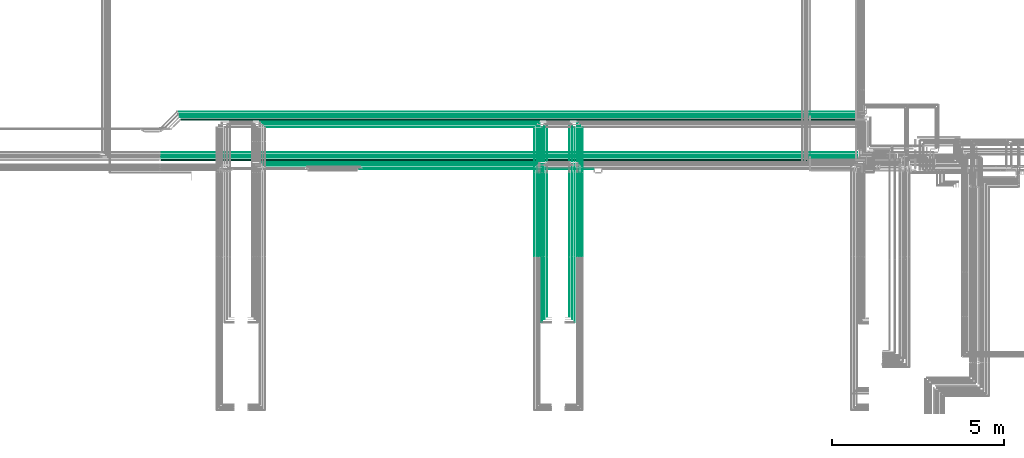
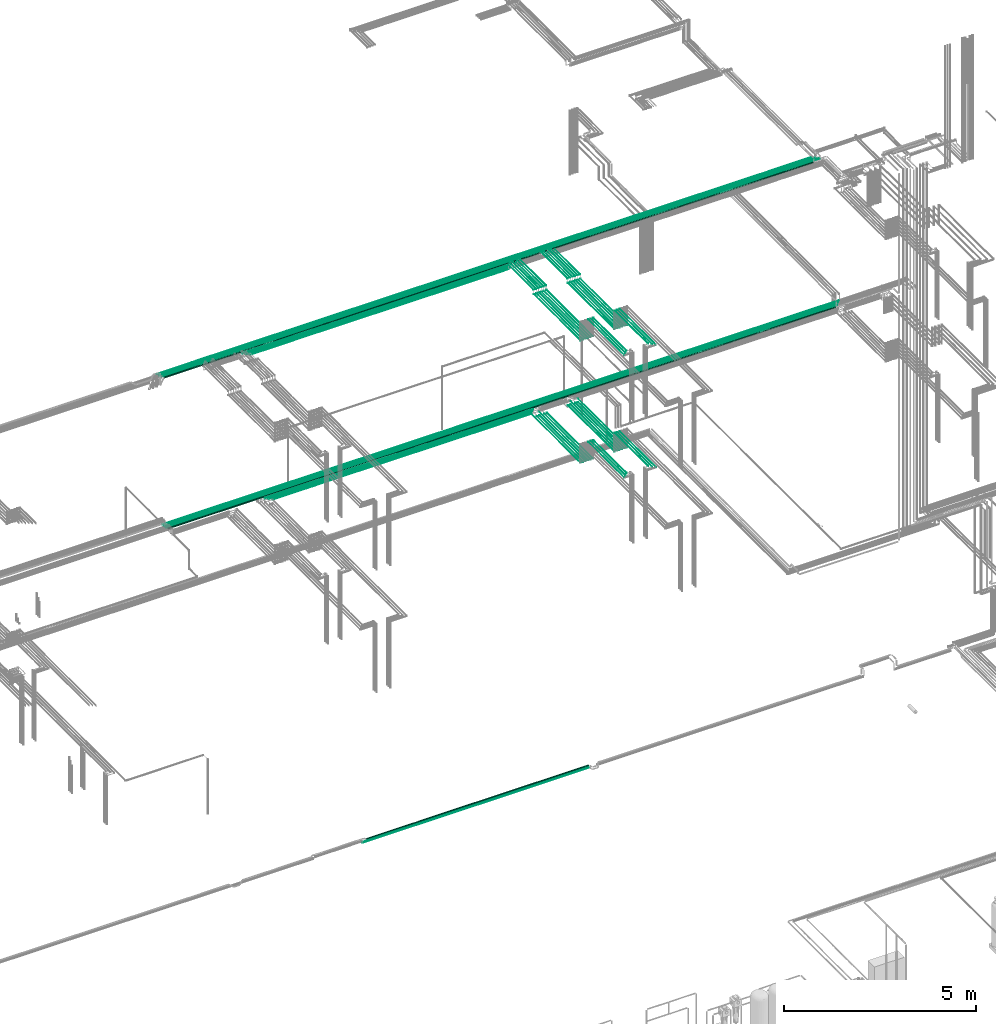
# One storey, part 63 of 331: 64 flow segments.
"""IFC2X3 building model written with IfcOpenShell, lengths in millimetres."""

from ifc_helpers import new_model, entity, si_unit, converted_unit, derived_unit, direction, frame, frame_2d, origin, origin_2d_with_axis, place, context, subcontext, project, spatial, circle, extrude, type_object, element, save


model = new_model("IFC2X3")

# Units and contexts
model_context = context("Model", 3, precision=0.01, world=origin(), true_north=direction((6.12303176911189e-17, 1.0)))
body_context = subcontext(model_context, "Body", "Model", "MODEL_VIEW")
ifc_project = project(units=[si_unit("LENGTHUNIT", "METRE", prefix="MILLI"), si_unit("AREAUNIT", "SQUARE_METRE"), si_unit("VOLUMEUNIT", "CUBIC_METRE"), converted_unit("PLANEANGLEUNIT", "DEGREE", entity("IfcRatioMeasure", 0.0174532925199433), si_unit("PLANEANGLEUNIT", "RADIAN"), dimensions=[0, 0, 0, 0, 0, 0, 0]), si_unit("MASSUNIT", "GRAM", prefix="KILO"), derived_unit("MASSDENSITYUNIT", [(si_unit("MASSUNIT", "GRAM", prefix="KILO"), 1), (si_unit("LENGTHUNIT", "METRE"), -3)]), derived_unit("MOMENTOFINERTIAUNIT", [(si_unit("LENGTHUNIT", "METRE"), 4)]), si_unit("TIMEUNIT", "SECOND"), si_unit("FREQUENCYUNIT", "HERTZ"), si_unit("THERMODYNAMICTEMPERATUREUNIT", "DEGREE_CELSIUS"), derived_unit("THERMALTRANSMITTANCEUNIT", [(si_unit("MASSUNIT", "GRAM", prefix="KILO"), 1), (si_unit("THERMODYNAMICTEMPERATUREUNIT", "KELVIN"), -1), (si_unit("TIMEUNIT", "SECOND"), -3)]), derived_unit("VOLUMETRICFLOWRATEUNIT", [(si_unit("LENGTHUNIT", "METRE"), 3), (si_unit("TIMEUNIT", "SECOND"), -1)]), derived_unit("MASSFLOWRATEUNIT", [(si_unit("MASSUNIT", "GRAM", prefix="KILO"), 1), (si_unit("TIMEUNIT", "SECOND"), -1)]), derived_unit("ROTATIONALFREQUENCYUNIT", [(si_unit("TIMEUNIT", "SECOND"), -1)]), si_unit("ELECTRICCURRENTUNIT", "AMPERE"), si_unit("ELECTRICVOLTAGEUNIT", "VOLT"), si_unit("POWERUNIT", "WATT"), si_unit("FORCEUNIT", "NEWTON", prefix="KILO"), si_unit("ILLUMINANCEUNIT", "LUX"), si_unit("LUMINOUSFLUXUNIT", "LUMEN"), si_unit("LUMINOUSINTENSITYUNIT", "CANDELA"), derived_unit("USERDEFINED", [(si_unit("MASSUNIT", "GRAM", prefix="KILO"), -1), (si_unit("LENGTHUNIT", "METRE"), -2), (si_unit("TIMEUNIT", "SECOND"), 3), (si_unit("LUMINOUSFLUXUNIT", "LUMEN"), 1)]), derived_unit("LINEARVELOCITYUNIT", [(si_unit("LENGTHUNIT", "METRE"), 1), (si_unit("TIMEUNIT", "SECOND"), -1)]), si_unit("PRESSUREUNIT", "PASCAL"), derived_unit("USERDEFINED", [(si_unit("LENGTHUNIT", "METRE"), -2), (si_unit("MASSUNIT", "GRAM", prefix="KILO"), 1), (si_unit("TIMEUNIT", "SECOND"), -2)]), derived_unit("LINEARFORCEUNIT", [(si_unit("MASSUNIT", "GRAM", prefix="KILO"), 1), (si_unit("LENGTHUNIT", "METRE"), 1), (si_unit("TIMEUNIT", "SECOND"), -2), (si_unit("LENGTHUNIT", "METRE"), -1)]), derived_unit("PLANARFORCEUNIT", [(si_unit("MASSUNIT", "GRAM", prefix="KILO"), 1), (si_unit("LENGTHUNIT", "METRE"), 1), (si_unit("TIMEUNIT", "SECOND"), -2), (si_unit("LENGTHUNIT", "METRE"), -2)])], contexts=[model_context])

# Site, building, storey
site_placement = place(None, frame((0.0, -0.00077364408347762, 0.0)))
site = spatial("IfcSite", under=ifc_project, at=site_placement, CompositionType="ELEMENT")
building_placement = place(site_placement, origin())
building = spatial("IfcBuilding", under=site, at=building_placement, CompositionType="ELEMENT")
storey_placement = place(building_placement, origin())
storey = spatial("IfcBuildingStorey", under=building, at=storey_placement, CompositionType="ELEMENT", Elevation=0.0)

# Flow segments
pipe_segment_type = type_object("IfcPipeSegmentType", PredefinedType="NOTDEFINED")
flow_segment_1_placement = place(storey_placement, frame((41835.1806039076, 8668.02529159145, 14542.4047277641)))
element("IfcFlowSegment", 1, at=flow_segment_1_placement, inside=storey, type_object=pipe_segment_type, context=body_context, shape_type="SweptSolid", body=[
    extrude(circle(Radius=6.0, at=frame_2d((0.0, 2.16573425859679e-12), x_axis=(1.0, 0.0))), frame((0.0, 7.59527223591562, 7.59527223591454), z_axis=(1.0, 0.0, 0.0), x_axis=(0.0, 1.0, 0.0)), (0.0, 0.0, 1.0), 20377.9279273853),
])
flow_segment_2_placement = place(storey_placement, frame((53840.5223318378, 5653.62056382735, 14544.4047277641)))
element("IfcFlowSegment", 2, at=flow_segment_2_placement, inside=storey, type_object=pipe_segment_type, context=body_context, shape_type="SweptSolid", body=[
    extrude(circle(Radius=4.0, at=origin_2d_with_axis()), frame((5.59527223594098, 0.0, 5.59527223591499), z_axis=(0.0, 1.0, 0.0), x_axis=(1.0, 0.0, 0.0)), (0.0, 0.0, 1.0), 2559.0),
])
flow_segment_3_placement = place(storey_placement, frame((54065.5223318378, 5653.62056382734, 14544.4047277641)))
element("IfcFlowSegment", 3, at=flow_segment_3_placement, inside=storey, type_object=pipe_segment_type, context=body_context, shape_type="SweptSolid", body=[
    extrude(circle(Radius=4.0, at=origin_2d_with_axis()), frame((5.59527223593232, 0.0, 5.59527223591499), z_axis=(0.0, 1.0, 0.0), x_axis=(1.0, 0.0, 0.0)), (0.0, 0.0, 1.0), 2559.0),
])
for number, where in (
    (4, (53765.5223318378, 5653.62056382735, 14544.4047277641)),
    (5, (53990.5223318378, 5653.62056382735, 14544.4047277641)),
):
    element("IfcFlowSegment", number, at=place(storey_placement, frame(where)), inside=storey, type_object=pipe_segment_type, context=body_context, shape_type="SweptSolid", body=[
        extrude(circle(Radius=4.0, at=origin_2d_with_axis()), frame((5.59527223591499, 0.0, 5.59527223591499), z_axis=(0.0, 1.0, 0.0), x_axis=(-1.0, 0.0, 0.0)), (0.0, 0.0, 1.0), 2422.38938002197),
    ])
flow_segment_4_placement = place(storey_placement, frame((53688.5223318378, 5657.62056382735, 14542.4047277641)))
element("IfcFlowSegment", 6, at=flow_segment_4_placement, inside=storey, type_object=pipe_segment_type, context=body_context, shape_type="SweptSolid", body=[
    extrude(circle(Radius=6.0, at=frame_2d((8.66293703438714e-12, -2.16573425859679e-12), x_axis=(1.0, 0.0))), frame((7.5952722359232, 0.0, 7.59527223591887), z_axis=(0.0, 1.0, 0.0), x_axis=(-1.0, 0.0, 0.0)), (0.0, 0.0, 1.0), 2414.00000000002),
])
flow_segment_5_placement = place(storey_placement, frame((53913.5223318378, 5657.62056382735, 14542.4047277641)))
element("IfcFlowSegment", 7, at=flow_segment_5_placement, inside=storey, type_object=pipe_segment_type, context=body_context, shape_type="SweptSolid", body=[
    extrude(circle(Radius=6.0, at=frame_2d((0.0, -2.16573425859679e-12), x_axis=(1.0, 0.0))), frame((7.59527223591454, 0.0, 7.59527223591887), z_axis=(0.0, 1.0, 0.0), x_axis=(-1.0, 0.0, 0.0)), (0.0, 0.0, 1.0), 2414.00000000001),
])
flow_segment_6_placement = place(storey_placement, frame((53688.5223318378, 3905.48876707954, 15142.4047277641)))
element("IfcFlowSegment", 8, at=flow_segment_6_placement, inside=storey, type_object=pipe_segment_type, context=body_context, shape_type="SweptSolid", body=[
    extrude(circle(Radius=6.0, at=frame_2d((0.0, 2.16573425859679e-12), x_axis=(1.0, 0.0))), frame((7.59527223591454, 0.0, 7.59527223591887), z_axis=(0.0, 1.0, 0.0), x_axis=(1.0, 0.0, 0.0)), (0.0, 0.0, 1.0), 1724.13179674781),
])
flow_segment_7_placement = place(storey_placement, frame((53765.5223318378, 3826.48876707969, 15144.4047277641)))
element("IfcFlowSegment", 9, at=flow_segment_7_placement, inside=storey, type_object=pipe_segment_type, context=body_context, shape_type="SweptSolid", body=[
    extrude(circle(Radius=4.0, at=origin_2d_with_axis()), frame((5.59527223591499, 0.0, 5.59527223591499), z_axis=(0.0, 1.0, 0.0), x_axis=(1.0, 0.0, 0.0)), (0.0, 0.0, 1.0), 1807.13179674766),
])
flow_segment_8_placement = place(storey_placement, frame((53840.5223318378, 3751.48876707946, 15144.4047277641)))
element("IfcFlowSegment", 10, at=flow_segment_8_placement, inside=storey, type_object=pipe_segment_type, context=body_context, shape_type="SweptSolid", body=[
    extrude(circle(Radius=4.0, at=origin_2d_with_axis()), frame((5.59527223591499, 0.0, 5.59527223591499), z_axis=(0.0, 1.0, 0.0), x_axis=(1.0, 0.0, 0.0)), (0.0, 0.0, 1.0), 1882.13179674789),
])
flow_segment_9_placement = place(storey_placement, frame((52890.0441030245, 5653.62056382735, 14544.4047277641)))
element("IfcFlowSegment", 11, at=flow_segment_9_placement, inside=storey, type_object=pipe_segment_type, context=body_context, shape_type="SweptSolid", body=[
    extrude(circle(Radius=4.0, at=origin_2d_with_axis()), frame((5.59527223590633, 0.0, 5.59527223591499), z_axis=(0.0, 1.0, 0.0), x_axis=(1.0, 0.0, 0.0)), (0.0, 0.0, 1.0), 2559.0),
])
flow_segment_10_placement = place(storey_placement, frame((52665.0441030245, 5653.62056382735, 14544.4047277641)))
element("IfcFlowSegment", 12, at=flow_segment_10_placement, inside=storey, type_object=pipe_segment_type, context=body_context, shape_type="SweptSolid", body=[
    extrude(circle(Radius=4.0, at=origin_2d_with_axis()), frame((5.59527223591499, 0.0, 5.59527223591499), z_axis=(0.0, 1.0, 0.0), x_axis=(1.0, 0.0, 0.0)), (0.0, 0.0, 1.0), 2559.0),
])
for number, where in (
    (13, (52965.0441030245, 5653.62056382735, 14544.4047277641)),
    (14, (52740.0441030245, 5653.62056382735, 14544.4047277641)),
):
    element("IfcFlowSegment", number, at=place(storey_placement, frame(where)), inside=storey, type_object=pipe_segment_type, context=body_context, shape_type="SweptSolid", body=[
        extrude(circle(Radius=4.0, at=origin_2d_with_axis()), frame((5.59527223591499, 0.0, 5.59527223591499), z_axis=(0.0, 1.0, 0.0), x_axis=(-1.0, 0.0, 0.0)), (0.0, 0.0, 1.0), 2402.38938002197),
    ])
flow_segment_11_placement = place(storey_placement, frame((53038.0441030244, 5657.62056382735, 14542.4047277641)))
element("IfcFlowSegment", 15, at=flow_segment_11_placement, inside=storey, type_object=pipe_segment_type, context=body_context, shape_type="SweptSolid", body=[
    extrude(circle(Radius=6.0, at=frame_2d((-8.66293703438714e-12, -2.16573425859679e-12), x_axis=(1.0, 0.0))), frame((7.5952722359232, 0.0, 7.59527223591887), z_axis=(0.0, 1.0, 0.0), x_axis=(-1.0, 0.0, 0.0)), (0.0, 0.0, 1.0), 2394.00000000002),
])
flow_segment_12_placement = place(storey_placement, frame((52813.0441030245, 5657.62056382735, 14542.4047277641)))
element("IfcFlowSegment", 16, at=flow_segment_12_placement, inside=storey, type_object=pipe_segment_type, context=body_context, shape_type="SweptSolid", body=[
    extrude(circle(Radius=6.0, at=frame_2d((0.0, -2.16573425859679e-12), x_axis=(1.0, 0.0))), frame((7.59527223591454, 0.0, 7.59527223591887), z_axis=(0.0, 1.0, 0.0), x_axis=(-1.0, 0.0, 0.0)), (0.0, 0.0, 1.0), 2394.00000000001),
])
flow_segment_13_placement = place(storey_placement, frame((53038.0441030244, 3905.48876707956, 15142.4047277641)))
element("IfcFlowSegment", 17, at=flow_segment_13_placement, inside=storey, type_object=pipe_segment_type, context=body_context, shape_type="SweptSolid", body=[
    extrude(circle(Radius=6.0, at=frame_2d((0.0, 2.16573425859679e-12), x_axis=(1.0, 0.0))), frame((7.59527223591454, 0.0, 7.59527223591887), z_axis=(0.0, 1.0, 0.0), x_axis=(1.0, 0.0, 0.0)), (0.0, 0.0, 1.0), 1724.13179674779),
])
flow_segment_14_placement = place(storey_placement, frame((52965.0441030245, 3826.48876707969, 15144.4047277641)))
element("IfcFlowSegment", 18, at=flow_segment_14_placement, inside=storey, type_object=pipe_segment_type, context=body_context, shape_type="SweptSolid", body=[
    extrude(circle(Radius=4.0, at=origin_2d_with_axis()), frame((5.59527223591499, 0.0, 5.59527223591499), z_axis=(0.0, 1.0, 0.0), x_axis=(1.0, 0.0, 0.0)), (0.0, 0.0, 1.0), 1807.13179674766),
])
flow_segment_15_placement = place(storey_placement, frame((52890.0441030245, 3751.4887670795, 15144.4047277641)))
element("IfcFlowSegment", 19, at=flow_segment_15_placement, inside=storey, type_object=pipe_segment_type, context=body_context, shape_type="SweptSolid", body=[
    extrude(circle(Radius=4.0, at=origin_2d_with_axis()), frame((5.59527223591499, 0.0, 5.59527223591499), z_axis=(0.0, 1.0, 0.0), x_axis=(1.0, 0.0, 0.0)), (0.0, 0.0, 1.0), 1882.13179674785),
])
flow_segment_16_placement = place(storey_placement, frame((44877.2323745011, 8218.02529159143, 14542.4047277641)))
element("IfcFlowSegment", 20, at=flow_segment_16_placement, inside=storey, type_object=pipe_segment_type, context=body_context, shape_type="SweptSolid", body=[
    extrude(circle(Radius=6.0, at=frame_2d((-1.08286712929839e-12, 0.0), x_axis=(1.0, 0.0))), frame((0.0, 7.59527223591454, 7.5952722359167), z_axis=(1.0, 0.0, 0.0), x_axis=(0.0, -1.0, 0.0)), (0.0, 0.0, 1.0), 7786.4070007593),
])
flow_segment_17_placement = place(storey_placement, frame((44802.2303826997, 8293.02529159145, 14542.4042010996)))
element("IfcFlowSegment", 21, at=flow_segment_17_placement, inside=storey, type_object=pipe_segment_type, context=body_context, shape_type="SweptSolid", body=[
    extrude(circle(Radius=6.0, at=origin_2d_with_axis()), frame((0.000126456651605622, 7.59527223591562, 7.59527223458478), z_axis=(1.0, 0.0, 2.10761091309566e-05), x_axis=(0.0, -1.0, 0.0)), (0.0, 0.0, 1.0), 7936.40699893471),
])
flow_segment_18_placement = place(storey_placement, frame((44728.2303244212, 8366.52529159144, 14540.9040592844)))
element("IfcFlowSegment", 22, at=flow_segment_18_placement, inside=storey, type_object=pipe_segment_type, context=body_context, shape_type="SweptSolid", body=[
    extrude(circle(Radius=7.5, at=origin_2d_with_axis()), frame((0.000168554696574574, 9.09527223591636, 9.09527223402134), z_axis=(1.0, 0.0, 2.24739589642137e-05), x_axis=(0.0, -1.0, 0.0)), (0.0, 0.0, 1.0), 8084.40699860948),
])
flow_segment_19_placement = place(storey_placement, frame((41835.1806039076, 8593.02529159145, 14542.4047277641)))
element("IfcFlowSegment", 23, at=flow_segment_19_placement, inside=storey, type_object=pipe_segment_type, context=body_context, shape_type="SweptSolid", body=[
    extrude(circle(Radius=6.0, at=frame_2d((2.16573425859679e-12, -2.16573425859679e-12), x_axis=(1.0, 0.0))), frame((0.0, 7.59527223591778, 7.59527223591887), z_axis=(1.0, 0.0, 0.0), x_axis=(0.0, 1.0, 0.0)), (0.0, 0.0, 1.0), 20302.9279273852),
])
flow_segment_20_placement = place(storey_placement, frame((41845.1806039076, 8513.02529159144, 14537.4047277641)))
element("IfcFlowSegment", 24, at=flow_segment_20_placement, inside=storey, type_object=pipe_segment_type, context=body_context, shape_type="SweptSolid", body=[
    extrude(circle(Radius=11.0, at=frame_2d((2.16573425859679e-12, 0.0), x_axis=(1.0, 0.0))), frame((0.0, 12.5952722359177, 12.5952722359156), z_axis=(1.0, 0.0, 0.0), x_axis=(0.0, 1.0, 0.0)), (0.0, 0.0, 1.0), 20212.9279273852),
])
flow_segment_21_placement = place(storey_placement, frame((41861.1806039076, 8431.52529159142, 14530.904727764)))
element("IfcFlowSegment", 25, at=flow_segment_21_placement, inside=storey, type_object=pipe_segment_type, context=body_context, shape_type="SweptSolid", body=[
    extrude(circle(Radius=17.5, at=frame_2d((7.58006990508875e-12, 0.0), x_axis=(1.0, 0.0))), frame((0.0, 19.0952722359238, 19.0952722359163), z_axis=(1.0, 0.0, 0.0), x_axis=(0.0, 1.0, 0.0)), (0.0, 0.0, 1.0), 20112.9279273852),
])
flow_segment_22_placement = place(storey_placement, frame((52889.4468045266, 5653.62056382731, 18444.404727764)))
element("IfcFlowSegment", 26, at=flow_segment_22_placement, inside=storey, type_object=pipe_segment_type, context=body_context, shape_type="SweptSolid", body=[
    extrude(circle(Radius=4.0, at=origin_2d_with_axis()), frame((5.59527223591499, 0.0, 5.59527223591499), z_axis=(0.0, 1.0, 0.0), x_axis=(1.0, 0.0, 0.0)), (0.0, 0.0, 1.0), 2426.52824282761),
])
flow_segment_23_placement = place(storey_placement, frame((52664.4468045266, 5653.62056382731, 18444.4047277641)))
element("IfcFlowSegment", 27, at=flow_segment_23_placement, inside=storey, type_object=pipe_segment_type, context=body_context, shape_type="SweptSolid", body=[
    extrude(circle(Radius=4.0, at=frame_2d((8.66293703438714e-12, 0.0), x_axis=(1.0, 0.0))), frame((5.59527223591499, 0.0, 5.59527223591499), z_axis=(0.0, 1.0, 0.0), x_axis=(-1.0, 0.0, 0.0)), (0.0, 0.0, 1.0), 2426.52824282753),
])
flow_segment_24_placement = place(storey_placement, frame((52964.4468045266, 5653.62056382732, 18444.4047277641)))
element("IfcFlowSegment", 28, at=flow_segment_24_placement, inside=storey, type_object=pipe_segment_type, context=body_context, shape_type="SweptSolid", body=[
    extrude(circle(Radius=4.0, at=origin_2d_with_axis()), frame((5.59527223591499, 0.0, 5.59527223591499), z_axis=(0.0, 1.0, 0.0), x_axis=(1.0, 0.0, 0.0)), (0.0, 0.0, 1.0), 2426.5282428276),
])
flow_segment_25_placement = place(storey_placement, frame((52739.4468045266, 5653.62056382732, 18444.4047277641)))
element("IfcFlowSegment", 29, at=flow_segment_25_placement, inside=storey, type_object=pipe_segment_type, context=body_context, shape_type="SweptSolid", body=[
    extrude(circle(Radius=4.0, at=origin_2d_with_axis()), frame((5.59527223591499, 0.0, 5.59527223591499), z_axis=(0.0, 1.0, 0.0), x_axis=(-1.0, 0.0, 0.0)), (0.0, 0.0, 1.0), 2426.52824282759),
])
flow_segment_26_placement = place(storey_placement, frame((53037.4468045266, 5657.62056382733, 18442.4047277641)))
element("IfcFlowSegment", 30, at=flow_segment_26_placement, inside=storey, type_object=pipe_segment_type, context=body_context, shape_type="SweptSolid", body=[
    extrude(circle(Radius=6.0, at=origin_2d_with_axis()), frame((7.59527223591454, 0.0, 7.5952722359167), z_axis=(0.0, 1.0, 0.0), x_axis=(1.0, 0.0, 0.0)), (0.0, 0.0, 1.0), 2418.52824282759),
])
flow_segment_27_placement = place(storey_placement, frame((52812.4468045266, 5657.62056382732, 18442.4047277641)))
element("IfcFlowSegment", 31, at=flow_segment_27_placement, inside=storey, type_object=pipe_segment_type, context=body_context, shape_type="SweptSolid", body=[
    extrude(circle(Radius=6.0, at=origin_2d_with_axis()), frame((7.59527223591454, 0.0, 7.5952722359167), z_axis=(0.0, 1.0, 0.0), x_axis=(1.0, 0.0, 0.0)), (0.0, 0.0, 1.0), 2418.52824282761),
])
flow_segment_28_placement = place(storey_placement, frame((53037.4468045266, 3905.48876707967, 19042.4047277641)))
element("IfcFlowSegment", 32, at=flow_segment_28_placement, inside=storey, type_object=pipe_segment_type, context=body_context, shape_type="SweptSolid", body=[
    extrude(circle(Radius=6.0, at=origin_2d_with_axis()), frame((7.59527223591454, 0.0, 7.5952722359167), z_axis=(0.0, 1.0, 0.0), x_axis=(1.0, 0.0, 0.0)), (0.0, 0.0, 1.0), 1724.13179674766),
])
flow_segment_29_placement = place(storey_placement, frame((52964.4468045266, 3826.48876707966, 19044.4047277641)))
element("IfcFlowSegment", 33, at=flow_segment_29_placement, inside=storey, type_object=pipe_segment_type, context=body_context, shape_type="SweptSolid", body=[
    extrude(circle(Radius=4.0, at=origin_2d_with_axis()), frame((5.59527223591499, 0.0, 5.59527223591499), z_axis=(0.0, 1.0, 0.0), x_axis=(1.0, 0.0, 0.0)), (0.0, 0.0, 1.0), 1807.13179674766),
])
flow_segment_30_placement = place(storey_placement, frame((52889.4468045266, 3751.48876707966, 19044.4047277641)))
element("IfcFlowSegment", 34, at=flow_segment_30_placement, inside=storey, type_object=pipe_segment_type, context=body_context, shape_type="SweptSolid", body=[
    extrude(circle(Radius=4.0, at=origin_2d_with_axis()), frame((5.59527223591499, 0.0, 5.59527223591499), z_axis=(0.0, 1.0, 0.0), x_axis=(1.0, 0.0, 0.0)), (0.0, 0.0, 1.0), 1882.13179674766),
])
flow_segment_31_placement = place(storey_placement, frame((52664.4468045266, 8100.14880665483, 18574.4047277641)))
element("IfcFlowSegment", 35, at=flow_segment_31_placement, inside=storey, type_object=pipe_segment_type, context=body_context, shape_type="SweptSolid", body=[
    extrude(circle(Radius=4.0, at=origin_2d_with_axis()), frame((5.59527223591499, 0.0, 5.59527223591499), z_axis=(0.0, 1.0, 0.0), x_axis=(-1.0, 0.0, 0.0)), (0.0, 0.0, 1.0), 1289.85119334509),
])
flow_segment_32_placement = place(storey_placement, frame((52739.4468045266, 8100.14880665483, 18574.4047277641)))
element("IfcFlowSegment", 36, at=flow_segment_32_placement, inside=storey, type_object=pipe_segment_type, context=body_context, shape_type="SweptSolid", body=[
    extrude(circle(Radius=4.0, at=origin_2d_with_axis()), frame((5.59527223591499, 0.0, 5.59527223591499), z_axis=(0.0, 1.0, 0.0), x_axis=(-1.0, 0.0, 0.0)), (0.0, 0.0, 1.0), 1364.85119334509),
])
flow_segment_33_placement = place(storey_placement, frame((52812.4468045266, 8104.14880665491, 18572.4047277641)))
element("IfcFlowSegment", 37, at=flow_segment_33_placement, inside=storey, type_object=pipe_segment_type, context=body_context, shape_type="SweptSolid", body=[
    extrude(circle(Radius=6.0, at=frame_2d((0.0, 2.16573425859679e-12), x_axis=(1.0, 0.0))), frame((7.59527223591454, 0.0, 7.59527223591887), z_axis=(0.0, 1.0, 0.0), x_axis=(-1.0, 0.0, 0.0)), (0.0, 0.0, 1.0), 1431.85119334506),
])
flow_segment_34_placement = place(storey_placement, frame((52889.4468045266, 8100.1488066549, 18574.4047277641)))
element("IfcFlowSegment", 38, at=flow_segment_34_placement, inside=storey, type_object=pipe_segment_type, context=body_context, shape_type="SweptSolid", body=[
    extrude(circle(Radius=4.0, at=frame_2d((0.0, 2.16573425859679e-12), x_axis=(1.0, 0.0))), frame((5.59527223591499, 0.0, 5.59527223591716), z_axis=(0.0, 1.0, 0.0), x_axis=(-1.0, 0.0, 0.0)), (0.0, 0.0, 1.0), 1289.85119334502),
])
flow_segment_35_placement = place(storey_placement, frame((52964.4468045266, 8100.14880665491, 18574.4047277641)))
element("IfcFlowSegment", 39, at=flow_segment_35_placement, inside=storey, type_object=pipe_segment_type, context=body_context, shape_type="SweptSolid", body=[
    extrude(circle(Radius=4.0, at=origin_2d_with_axis()), frame((5.59527223591499, 0.0, 5.59527223591499), z_axis=(0.0, 1.0, 0.0), x_axis=(-1.0, 0.0, 0.0)), (0.0, 0.0, 1.0), 1364.85119334502),
])
flow_segment_36_placement = place(storey_placement, frame((53037.4468045266, 8104.14880665491, 18572.4047277641)))
element("IfcFlowSegment", 40, at=flow_segment_36_placement, inside=storey, type_object=pipe_segment_type, context=body_context, shape_type="SweptSolid", body=[
    extrude(circle(Radius=6.0, at=frame_2d((0.0, -2.16573425859679e-12), x_axis=(1.0, 0.0))), frame((7.59527223591454, 0.0, 7.59527223591887), z_axis=(0.0, 1.0, 0.0), x_axis=(-1.0, 0.0, 0.0)), (0.0, 0.0, 1.0), 1431.85119334507),
])
flow_segment_37_placement = place(storey_placement, frame((53839.5706481368, 5653.62056382731, 18444.404727764)))
element("IfcFlowSegment", 41, at=flow_segment_37_placement, inside=storey, type_object=pipe_segment_type, context=body_context, shape_type="SweptSolid", body=[
    extrude(circle(Radius=4.0, at=origin_2d_with_axis()), frame((5.59527223592365, 0.0, 5.59527223591499), z_axis=(0.0, 1.0, 0.0), x_axis=(1.0, 0.0, 0.0)), (0.0, 0.0, 1.0), 2426.52824282761),
])
flow_segment_38_placement = place(storey_placement, frame((54064.5706481368, 5653.62056382731, 18444.4047277641)))
element("IfcFlowSegment", 42, at=flow_segment_38_placement, inside=storey, type_object=pipe_segment_type, context=body_context, shape_type="SweptSolid", body=[
    extrude(circle(Radius=4.0, at=origin_2d_with_axis()), frame((5.59527223591499, 0.0, 5.59527223591499), z_axis=(0.0, 1.0, 0.0), x_axis=(-1.0, 0.0, 0.0)), (0.0, 0.0, 1.0), 2426.52824282753),
])
flow_segment_39_placement = place(storey_placement, frame((53764.5706481368, 5653.62056382732, 18444.4047277641)))
element("IfcFlowSegment", 43, at=flow_segment_39_placement, inside=storey, type_object=pipe_segment_type, context=body_context, shape_type="SweptSolid", body=[
    extrude(circle(Radius=4.0, at=origin_2d_with_axis()), frame((5.59527223591499, 0.0, 5.59527223591499), z_axis=(0.0, 1.0, 0.0), x_axis=(1.0, 0.0, 0.0)), (0.0, 0.0, 1.0), 2426.5282428276),
])
flow_segment_40_placement = place(storey_placement, frame((53989.5706481368, 5653.62056382732, 18444.4047277641)))
element("IfcFlowSegment", 44, at=flow_segment_40_placement, inside=storey, type_object=pipe_segment_type, context=body_context, shape_type="SweptSolid", body=[
    extrude(circle(Radius=4.0, at=origin_2d_with_axis()), frame((5.59527223591499, 0.0, 5.59527223591499), z_axis=(0.0, 1.0, 0.0), x_axis=(-1.0, 0.0, 0.0)), (0.0, 0.0, 1.0), 2426.52824282759),
])
flow_segment_41_placement = place(storey_placement, frame((53687.5706481368, 5657.62056382733, 18442.4047277641)))
element("IfcFlowSegment", 45, at=flow_segment_41_placement, inside=storey, type_object=pipe_segment_type, context=body_context, shape_type="SweptSolid", body=[
    extrude(circle(Radius=6.0, at=origin_2d_with_axis()), frame((7.59527223591454, 0.0, 7.5952722359167), z_axis=(0.0, 1.0, 0.0), x_axis=(1.0, 0.0, 0.0)), (0.0, 0.0, 1.0), 2418.52824282759),
])
flow_segment_42_placement = place(storey_placement, frame((53912.5706481368, 5657.62056382732, 18442.4047277641)))
element("IfcFlowSegment", 46, at=flow_segment_42_placement, inside=storey, type_object=pipe_segment_type, context=body_context, shape_type="SweptSolid", body=[
    extrude(circle(Radius=6.0, at=origin_2d_with_axis()), frame((7.59527223591454, 0.0, 7.5952722359167), z_axis=(0.0, 1.0, 0.0), x_axis=(1.0, 0.0, 0.0)), (0.0, 0.0, 1.0), 2418.52824282761),
])
flow_segment_43_placement = place(storey_placement, frame((53687.5706481368, 3905.48876707967, 19042.4047277641)))
element("IfcFlowSegment", 47, at=flow_segment_43_placement, inside=storey, type_object=pipe_segment_type, context=body_context, shape_type="SweptSolid", body=[
    extrude(circle(Radius=6.0, at=origin_2d_with_axis()), frame((7.59527223591454, 0.0, 7.5952722359167), z_axis=(0.0, 1.0, 0.0), x_axis=(1.0, 0.0, 0.0)), (0.0, 0.0, 1.0), 1724.13179674766),
])
flow_segment_44_placement = place(storey_placement, frame((53764.5706481368, 3826.48876707966, 19044.4047277641)))
element("IfcFlowSegment", 48, at=flow_segment_44_placement, inside=storey, type_object=pipe_segment_type, context=body_context, shape_type="SweptSolid", body=[
    extrude(circle(Radius=4.0, at=origin_2d_with_axis()), frame((5.59527223591499, 0.0, 5.59527223591499), z_axis=(0.0, 1.0, 0.0), x_axis=(1.0, 0.0, 0.0)), (0.0, 0.0, 1.0), 1807.13179674766),
])
flow_segment_45_placement = place(storey_placement, frame((53839.5706481368, 3751.48876707966, 19044.4047277641)))
element("IfcFlowSegment", 49, at=flow_segment_45_placement, inside=storey, type_object=pipe_segment_type, context=body_context, shape_type="SweptSolid", body=[
    extrude(circle(Radius=4.0, at=origin_2d_with_axis()), frame((5.59527223591499, 0.0, 5.59527223591499), z_axis=(0.0, 1.0, 0.0), x_axis=(1.0, 0.0, 0.0)), (0.0, 0.0, 1.0), 1882.13179674766),
])
flow_segment_46_placement = place(storey_placement, frame((54064.5706481368, 8100.14880665483, 18574.4047277641)))
element("IfcFlowSegment", 50, at=flow_segment_46_placement, inside=storey, type_object=pipe_segment_type, context=body_context, shape_type="SweptSolid", body=[
    extrude(circle(Radius=4.0, at=origin_2d_with_axis()), frame((5.59527223591499, 0.0, 5.59527223591499), z_axis=(0.0, 1.0, 0.0), x_axis=(-1.0, 0.0, 0.0)), (0.0, 0.0, 1.0), 1289.85119334509),
])
flow_segment_47_placement = place(storey_placement, frame((53989.5706481368, 8100.14880665483, 18574.4047277641)))
element("IfcFlowSegment", 51, at=flow_segment_47_placement, inside=storey, type_object=pipe_segment_type, context=body_context, shape_type="SweptSolid", body=[
    extrude(circle(Radius=4.0, at=origin_2d_with_axis()), frame((5.59527223591499, 0.0, 5.59527223591499), z_axis=(0.0, 1.0, 0.0), x_axis=(-1.0, 0.0, 0.0)), (0.0, 0.0, 1.0), 1364.85119334509),
])
flow_segment_48_placement = place(storey_placement, frame((53912.5706481368, 8104.14880665491, 18572.4047277641)))
element("IfcFlowSegment", 52, at=flow_segment_48_placement, inside=storey, type_object=pipe_segment_type, context=body_context, shape_type="SweptSolid", body=[
    extrude(circle(Radius=6.0, at=frame_2d((0.0, 2.16573425859679e-12), x_axis=(1.0, 0.0))), frame((7.59527223591454, 0.0, 7.59527223591887), z_axis=(0.0, 1.0, 0.0), x_axis=(-1.0, 0.0, 0.0)), (0.0, 0.0, 1.0), 1431.85119334507),
])
flow_segment_49_placement = place(storey_placement, frame((53839.5706481368, 8100.1488066549, 18574.4047277641)))
element("IfcFlowSegment", 53, at=flow_segment_49_placement, inside=storey, type_object=pipe_segment_type, context=body_context, shape_type="SweptSolid", body=[
    extrude(circle(Radius=4.0, at=frame_2d((0.0, 2.16573425859679e-12), x_axis=(1.0, 0.0))), frame((5.59527223591499, 0.0, 5.59527223591716), z_axis=(0.0, 1.0, 0.0), x_axis=(-1.0, 0.0, 0.0)), (0.0, 0.0, 1.0), 1289.85119334502),
])
flow_segment_50_placement = place(storey_placement, frame((53764.5706481368, 8100.14880665491, 18574.4047277641)))
element("IfcFlowSegment", 54, at=flow_segment_50_placement, inside=storey, type_object=pipe_segment_type, context=body_context, shape_type="SweptSolid", body=[
    extrude(circle(Radius=4.0, at=origin_2d_with_axis()), frame((5.59527223591499, 0.0, 5.59527223591499), z_axis=(0.0, 1.0, 0.0), x_axis=(-1.0, 0.0, 0.0)), (0.0, 0.0, 1.0), 1364.85119334502),
])
flow_segment_51_placement = place(storey_placement, frame((53687.5706481368, 8104.14880665491, 18572.4047277641)))
element("IfcFlowSegment", 55, at=flow_segment_51_placement, inside=storey, type_object=pipe_segment_type, context=body_context, shape_type="SweptSolid", body=[
    extrude(circle(Radius=6.0, at=frame_2d((0.0, -2.16573425859679e-12), x_axis=(1.0, 0.0))), frame((7.59527223591454, 0.0, 7.59527223591887), z_axis=(0.0, 1.0, 0.0), x_axis=(-1.0, 0.0, 0.0)), (0.0, 0.0, 1.0), 1431.85119334507),
])
flow_segment_52_placement = place(storey_placement, frame((42325.0991002971, 9842.404727764, 18442.4047277641)))
element("IfcFlowSegment", 56, at=flow_segment_52_placement, inside=storey, type_object=pipe_segment_type, context=body_context, shape_type="SweptSolid", body=[
    extrude(circle(Radius=6.0, at=frame_2d((-2.59888111031614e-11, -2.16573425859679e-12), x_axis=(1.0, 0.0))), frame((0.0, 7.59527223594486, 7.59527223591887), z_axis=(1.0, 0.0, 0.0), x_axis=(0.0, 1.0, 0.0)), (0.0, 0.0, 1.0), 19732.0909382686),
])
flow_segment_53_placement = place(storey_placement, frame((42356.1651174751, 9767.404727764, 18442.4047277641)))
element("IfcFlowSegment", 57, at=flow_segment_53_placement, inside=storey, type_object=pipe_segment_type, context=body_context, shape_type="SweptSolid", body=[
    extrude(circle(Radius=6.0, at=frame_2d((-2.59888111031614e-11, 0.0), x_axis=(1.0, 0.0))), frame((0.0, 7.59527223594486, 7.5952722359167), z_axis=(1.0, 0.0, 0.0), x_axis=(0.0, 1.0, 0.0)), (0.0, 0.0, 1.0), 19776.0249210904),
])
flow_segment_54_placement = place(storey_placement, frame((42391.231134653, 9687.404727764, 18437.4047277641)))
element("IfcFlowSegment", 58, at=flow_segment_54_placement, inside=storey, type_object=pipe_segment_type, context=body_context, shape_type="SweptSolid", body=[
    extrude(circle(Radius=11.0, at=frame_2d((-2.59888111031614e-11, 0.0), x_axis=(1.0, 0.0))), frame((0.0, 12.5952722359405, 12.5952722359156), z_axis=(1.0, 0.0, 0.0), x_axis=(0.0, 1.0, 0.0)), (0.0, 0.0, 1.0), 19817.9589039127),
])
flow_segment_55_placement = place(storey_placement, frame((42427.297151831, 9605.904727764, 18430.9047277641)))
element("IfcFlowSegment", 59, at=flow_segment_55_placement, inside=storey, type_object=pipe_segment_type, context=body_context, shape_type="SweptSolid", body=[
    extrude(circle(Radius=17.5, at=frame_2d((-2.70716782324598e-11, 0.0), x_axis=(1.0, 0.0))), frame((0.0, 19.0952722359422, 19.0952722359163), z_axis=(1.0, 0.0, 0.0), x_axis=(0.0, 1.0, 0.0)), (0.0, 0.0, 1.0), 19547.8928867347),
])
flow_segment_56_placement = place(storey_placement, frame((44877.1659203728, 9392.404727764, 18442.4047277642)))
element("IfcFlowSegment", 60, at=flow_segment_56_placement, inside=storey, type_object=pipe_segment_type, context=body_context, shape_type="SweptSolid", body=[
    extrude(circle(Radius=6.0, at=frame_2d((-1.73258740687743e-11, 0.0), x_axis=(1.0, 0.0))), frame((0.0, 7.59527223593294, 7.5952722359167), z_axis=(1.0, 0.0, 0.0), x_axis=(0.0, 1.0, 0.0)), (0.0, 0.0, 1.0), 7785.87615638976),
])
flow_segment_57_placement = place(storey_placement, frame((44728.1659203727, 9540.90472776404, 18440.9047277642)))
element("IfcFlowSegment", 61, at=flow_segment_57_placement, inside=storey, type_object=pipe_segment_type, context=body_context, shape_type="SweptSolid", body=[
    extrude(circle(Radius=7.5, at=origin_2d_with_axis()), frame((0.0, 9.09527223591636, 9.09527223591636), z_axis=(1.0, 0.0, 0.0), x_axis=(0.0, -1.0, 0.0)), (0.0, 0.0, 1.0), 8083.87615638978),
])
flow_segment_58_placement = place(storey_placement, frame((44802.1659203728, 9467.404727764, 18442.4047277642)))
element("IfcFlowSegment", 62, at=flow_segment_58_placement, inside=storey, type_object=pipe_segment_type, context=body_context, shape_type="SweptSolid", body=[
    extrude(circle(Radius=6.0, at=frame_2d((1.08286712929839e-12, -2.16573425859679e-12), x_axis=(1.0, 0.0))), frame((0.0, 7.5952722359167, 7.59527223591887), z_axis=(1.0, 0.0, 0.0), x_axis=(0.0, 1.0, 0.0)), (0.0, 0.0, 1.0), 7935.87615638977),
])
flow_segment_59_placement = place(building_placement, frame((47699.3643734476, 8179.9209894566, 2759.40472776402)))
element("IfcFlowSegment", 63, at=flow_segment_59_placement, inside=storey, type_object=pipe_segment_type, context=body_context, shape_type="SweptSolid", body=[
    extrude(circle(Radius=14.0, at=frame_2d((1.08286712929839e-12, 0.0), x_axis=(1.0, 0.0))), frame((0.0, 15.595272235917, 15.595272235916), z_axis=(1.0, 0.0, 0.0), x_axis=(0.0, 1.0, 0.0)), (0.0, 0.0, 1.0), 6678.89515526092),
])
flow_segment_60_placement = place(building_placement, frame((47573.7983299503, 8182.92098945675, 2687.40472776403)))
element("IfcFlowSegment", 64, at=flow_segment_60_placement, inside=storey, type_object=pipe_segment_type, context=body_context, shape_type="SweptSolid", body=[
    extrude(circle(Radius=11.0, at=frame_2d((2.16573425859679e-12, -5.41433564649196e-13), x_axis=(1.0, 0.0))), frame((0.0, 12.5952722359177, 12.5952722359166), z_axis=(1.0, 0.0, 0.0), x_axis=(0.0, 1.0, 0.0)), (0.0, 0.0, 1.0), 6814.46119875821),
])

save(model, "model.ifc")
